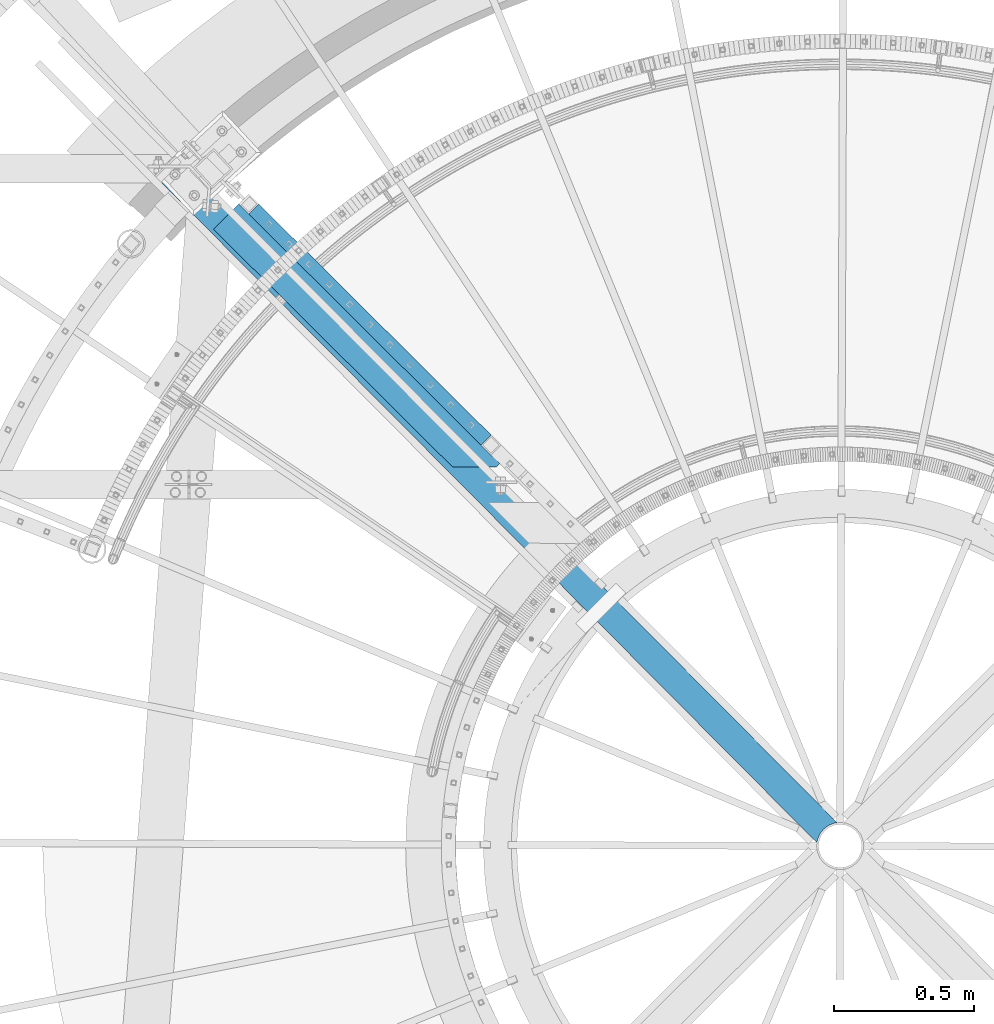
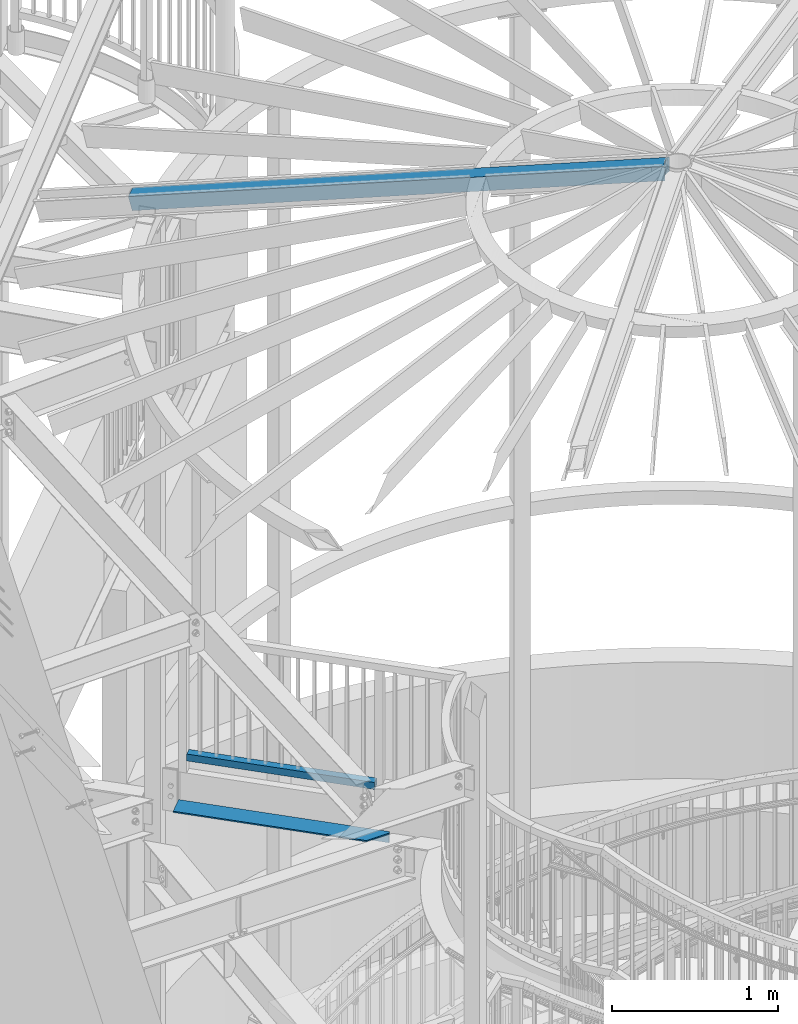
# One storey, part 352 of 975: 3 beams.
"""IFC2X3 building model written with IfcOpenShell, lengths in millimetres."""

from ifc_helpers import new_model, si_unit, frame, origin_with_axes, place, context, subcontext, project, spatial, faceted_brep, material, type_object, element, save


model = new_model("IFC2X3")

# Units and contexts
model_context = context("Model", 3, precision=1e-05, world=origin_with_axes())
body_context = subcontext(model_context, "Body", "Model", "MODEL_VIEW")
ifc_project = project(units=[si_unit("LENGTHUNIT", "METRE", prefix="MILLI"), si_unit("AREAUNIT", "SQUARE_METRE"), si_unit("VOLUMEUNIT", "CUBIC_METRE"), si_unit("MASSUNIT", "GRAM", prefix="KILO"), si_unit("TIMEUNIT", "SECOND"), si_unit("PLANEANGLEUNIT", "RADIAN"), si_unit("SOLIDANGLEUNIT", "STERADIAN"), si_unit("THERMODYNAMICTEMPERATUREUNIT", "DEGREE_CELSIUS"), si_unit("LUMINOUSINTENSITYUNIT", "LUMEN")], contexts=[model_context])

# Site, building, storey
site_placement = place(None, origin_with_axes())
site = spatial("IfcSite", under=ifc_project, at=site_placement, CompositionType="ELEMENT")
building_placement = place(site_placement, origin_with_axes())
building = spatial("IfcBuilding", under=site, at=building_placement, Name="Undefined", CompositionType="ELEMENT")
storey_placement = place(building_placement, origin_with_axes())
storey = spatial("IfcBuildingStorey", under=building, at=storey_placement, Name="Undefined", CompositionType="ELEMENT", Elevation=0.0)

# Beams
ifc_material_1 = material()
beam_type_1 = type_object("IfcBeamType", Name="HSS2X2X.188_TUBES", PredefinedType="NOTDEFINED")
beam_1_placement = place(storey_placement, frame((32625.107812017, 5693.25406560821, 4254.5), z_axis=(0.0, 0.0, 1.0), x_axis=(0.708992011834515, -0.705216510835394, 0.0)))
element("IfcBeam", 1, at=beam_1_placement, inside=storey, type_object=beam_type_1, material=ifc_material_1, Name="HANDRAIL", ObjectType="HSS2X2X.188_TUBES", context=body_context, shape_type="Brep", body=[
    faceted_brep([(25.3999997357314, 20.6374999999898, -20.6374999999998), (25.4000002641624, -20.6375000000153, -20.6374999999998), (1193.80000000563, -20.6375000001644, -20.6374999999998), (1193.80000000566, 20.6374999998443, -20.6374999999998), (25.4000002641624, -20.6375000000153, 20.6374999999998), (1193.80000000563, -20.6375000001644, 20.6374999999998), (25.3999997357314, 20.6374999999898, 20.6374999999998), (1193.80000000566, 20.6374999998443, 20.6374999999998), (25.4000003077635, 25.3999999999942, -25.3999999999996), (25.3999996747552, 25.3999999999905, 25.3999999999996), (1193.80000000567, 25.3999999998487, 25.3999999999996), (1193.80000000567, 25.3999999998487, -25.3999999999996), (25.4000003251349, -25.4000000000124, 25.3999999999996), (1193.80000000563, -25.4000000001652, 25.3999999999996), (25.4000003077854, -25.4000000000087, -25.3999999999996), (1193.80000000563, -25.4000000001652, -25.3999999999996)], [[[0, 1, 2, 3]], [[1, 4, 5, 2]], [[4, 6, 7, 5]], [[6, 0, 3, 7]], [[8, 9, 10, 11]], [[9, 12, 13, 10]], [[12, 14, 15, 13]], [[14, 8, 11, 15]], [[13, 15, 11, 10], [5, 7, 3, 2]], [[14, 12, 9, 8], [6, 4, 1, 0]]]),
])
ifc_material_2 = material(Name="STEEL/A36")
beam_type_2 = type_object("IfcBeamType", Name="L5X3X3/8", PredefinedType="NOTDEFINED")
beam_2_placement = place(storey_placement, frame((32544.3963604718, 5648.24455522109, 3898.9), z_axis=(-0.705216510835395, -0.708992011834513, 0.0), x_axis=(0.708992011834515, -0.705216510835394, 0.0)))
element("IfcBeam", 2, at=beam_2_placement, inside=storey, type_object=beam_type_2, material=ifc_material_2, Name="ANGLE", ObjectType="L5X3X3/8", context=body_context, shape_type="Brep", body=[
    faceted_brep([(5.0931703299284e-11, -38.0999999999999, -63.5000000000255), (4.36557456851006e-11, -38.0999999999999, -53.9750000000204), (4.36557456851006e-11, 28.5749999999998, -53.9750000000204), (-4.72937244921923e-11, 28.5749999999998, 63.5000000000182), (-4.72937244921923e-11, 38.0999999999999, 63.5000000000182), (5.0931703299284e-11, 38.0999999999999, -63.5000000000255), (1312.57242909241, 38.0999999999999, -63.4999999998508), (1312.57242909241, -38.0999999999999, -63.4999999998508), (1312.5724290924, -38.0999999999999, -53.9749999998494), (1312.5724290924, 28.5749999999998, -53.9749999998494), (1312.5724290924, 28.5749999999998, -47.3246556495797), (1201.15445409801, 28.5749999999998, 63.5000000001746), (1201.15445409801, 38.0999999999999, 63.5000000001746), (1312.5724290924, 38.0999999999999, -47.3246556495797)], [[[0, 1, 2, 3, 4, 5]], [[0, 5, 6, 7]], [[1, 0, 7, 8]], [[2, 1, 8, 9]], [[3, 2, 9, 10, 11]], [[4, 3, 11, 12]], [[6, 5, 4, 12, 13]], [[9, 8, 7, 6, 13, 10]], [[12, 11, 10, 13]]]),
])
beam_type_3 = type_object("IfcBeamType", Name="HSS4X4X3/8", PredefinedType="NOTDEFINED")
beam_3_placement = place(storey_placement, frame((32335.5786473553, 5820.16551486661, 8355.32707211838), z_axis=(-0.170873527176511, 0.172130267177808, 0.970140922150774), x_axis=(0.683475126987411, -0.688502112987316, 0.242541936995532)))
element("IfcBeam", 3, at=beam_3_placement, inside=storey, type_object=beam_type_3, material=ifc_material_1, Name="BEAM", ObjectType="HSS4X4X3/8", context=body_context, shape_type="Brep", body=[
    faceted_brep([(3438.83735812861, -22.0904176136246, 50.8000000013358), (3436.45604228348, -22.0904176085714, 41.2750000013289), (3433.41640701447, -0.308512534764304, 41.2750000013234), (3435.7977228596, -0.308512539817457, 50.8000000013285), (3436.29143033248, 21.4944170195777, 41.2750000013198), (3438.6727461776, 21.4944170145209, 50.8000000013249), (3454.30560025219, 50.8000000042775, 50.8000000013267), (3447.2664999947, 41.8325374313063, 50.8000000013249), (3421.8657976467, 41.8325374852029, -50.7999999987392), (3428.90489786185, 50.800000004263, -50.7999999987383), (3444.64959996888, 41.2750000042688, 41.275000001317), (3424.01152929259, 41.2750000042543, -41.274999998735), (3415.65335967472, 21.4944170633644, -41.2749999987323), (3413.27204382959, 21.4944170684175, -50.7999999987373), (3412.77833635671, -0.308512490973953, -41.2749999987295), (3410.39702051158, -0.308512485920801, -50.7999999987355), (3415.81797162572, -22.0904175647811, -41.2749999987223), (3413.43665578059, -22.0904175597279, -50.7999999987301), (3454.30536256338, -50.7999999956992, 50.8000000013449), (3428.90466025831, -50.7999999957137, -50.7999999987182), (3422.18380351628, -42.3668973185268, -50.7999999987219), (3447.58450586428, -42.3668973724198, 50.8000000013403), (3424.09408161953, -41.2749999957268, -41.2749999987177), (3444.7321522584, -41.2749999957123, 41.2750000013343), (6.3499999872256, 50.7999999999884, 50.8000000000225), (6.35000001109802, -50.799999999992, 50.8000000000425), (6.34999999362844, -50.7999999999738, -50.8000000000134), (6.34999996975966, 50.8000000000065, -50.8000000000334), (6.34999998782587, 41.2749999999942, 41.2750000000183), (6.35000000721993, -41.2749999999905, 41.2750000000347), (6.34999999302818, -41.274999999976, -41.2750000000101), (6.34999997363047, 41.2750000000087, -41.2750000000256)], [[[0, 1, 2, 3]], [[3, 2, 4, 5]], [[6, 7, 8, 9]], [[5, 4, 10, 11, 12, 13, 8, 7]], [[14, 15, 13, 12]], [[16, 17, 15, 14]], [[18, 19, 20, 21]], [[21, 20, 17, 16, 22, 23, 1, 0]], [[0, 3, 5, 7, 6, 24, 25, 18, 21]], [[26, 27, 9, 8, 13, 15, 17, 20, 19]], [[25, 26, 19, 18]], [[27, 24, 6, 9]], [[26, 25, 24, 27], [28, 29, 30, 31]], [[30, 29, 23, 22]], [[14, 12, 11, 31, 30, 22, 16]], [[28, 31, 11, 10]], [[29, 28, 10, 4, 2, 1, 23]]]),
])

save(model, "model.ifc")
